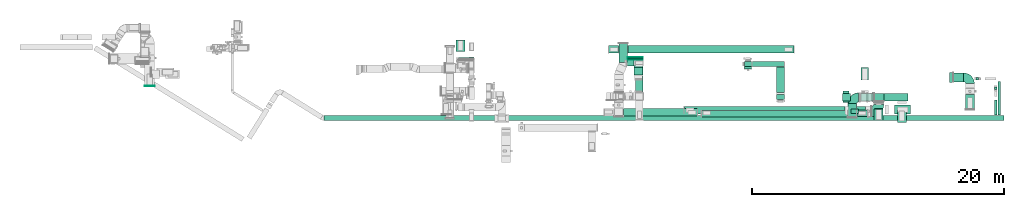
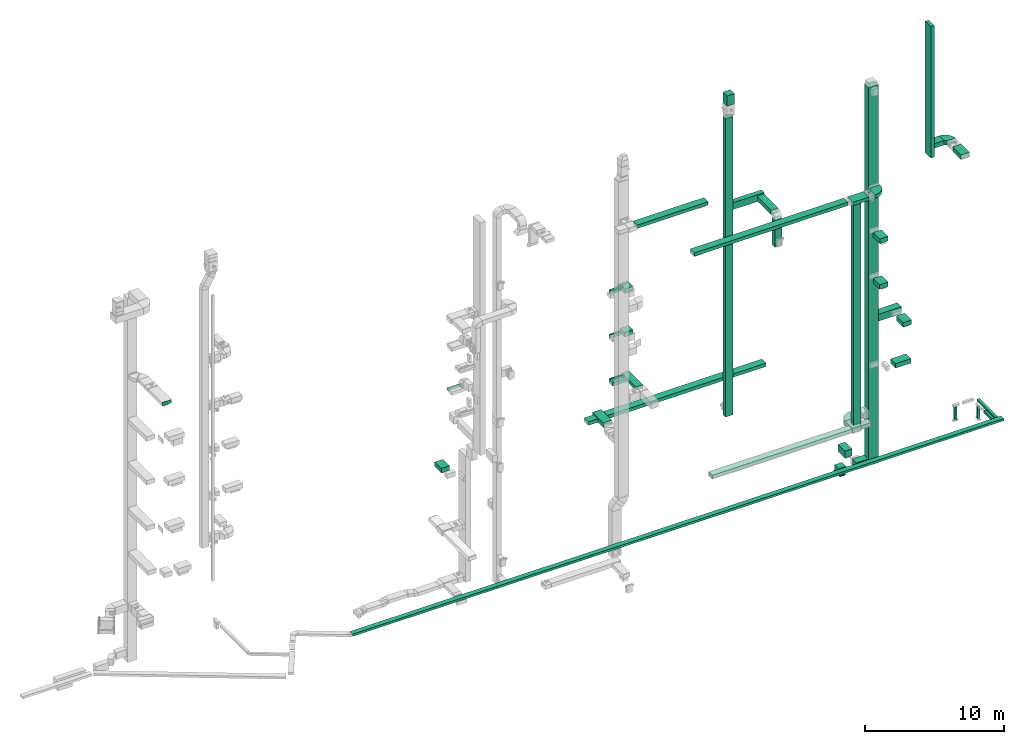
# One storey, part 8 of 25: 42 flow segments, 7 flow fittings, 2 flow terminals.
"""IFC2X3 building model written with IfcOpenShell, lengths in millimetres."""

import ifcopenshell
import ifcopenshell.guid

model = None  # the IFC model being written
_history = None  # IfcOwnerHistory: only IFC2X3 demands one
_inside = {}  # id of a spatial element -> (the spatial element, [elements in it])
_under = {}  # id of a project, library or spatial element -> (it, [spatial elements below it])
_declared = {}  # id of a project -> (the project, [libraries it declares])
_typed = {}  # id of a type object -> (the type object, [elements of that type])
_made_of = {}  # id of a material, layer set ... -> (it, [elements and type objects made of it])


def new_model(schema):
    """Start an empty IFC model of exactly this schema.

    Asked for "IFC4X3", IfcOpenShell would pick the latest addendum, in which some entities
    have other attributes; the version numbers below select the first issue.
    IFC2X3 requires an IfcOwnerHistory on every rooted entity: one is made here for all.
    """
    global model, _history
    if schema == "IFC4X3":
        model = ifcopenshell.file(schema_version=(4, 3, 0, 0))
    else:
        model = ifcopenshell.file(schema=schema)
    _inside.clear()
    _under.clear()
    _declared.clear()
    _typed.clear()
    _made_of.clear()
    _history = None
    if model.schema == "IFC2X3":
        org = make("IfcOrganization", Name="unknown")
        user = make(
            "IfcPersonAndOrganization",
            ThePerson=make("IfcPerson", FamilyName="unknown"),
            TheOrganization=org,
        )
        app = make(
            "IfcApplication",
            ApplicationDeveloper=org,
            Version="unknown",
            ApplicationFullName="unknown",
            ApplicationIdentifier="unknown",
        )
        _history = make(
            "IfcOwnerHistory",
            OwningUser=user,
            OwningApplication=app,
            ChangeAction="ADDED",
            CreationDate=0,
        )
    return model


def make(cls, **values):
    """One entity of the class cls with the attributes given. An attribute that is None is left unset."""
    return model.create_entity(
        cls, **{name: value for name, value in values.items() if value is not None}
    )


def entity(cls, *values):
    """Any entity or typed value of the class cls, its attributes in the order of the schema. None: left unset."""
    e = model.create_entity(cls)
    for i, value in enumerate(values):
        if value is not None:
            e[i] = value
    return e


def rooted(cls, **values):
    """An entity with a GlobalId (a new one), such as an element, a storey or a relation."""
    return make(cls, GlobalId=ifcopenshell.guid.new(), OwnerHistory=_history, **values)


def si_unit(unit_type, name, prefix=None):
    """IfcSIUnit, for example si_unit("LENGTHUNIT", "METRE", prefix="MILLI")."""
    return make("IfcSIUnit", UnitType=unit_type, Prefix=prefix, Name=name)


def converted_unit(unit_type, name, factor, base, dimensions=None, offset=None):
    """IfcConversionBasedUnit, such as the inch: factor (a typed value) times the base unit."""
    return make(
        "IfcConversionBasedUnit"
        if offset is None
        else "IfcConversionBasedUnitWithOffset",
        ConversionOffset=offset,
        Dimensions=None
        if dimensions is None
        else entity("IfcDimensionalExponents", *dimensions),
        UnitType=unit_type,
        Name=name,
        ConversionFactor=make(
            "IfcMeasureWithUnit", ValueComponent=factor, UnitComponent=base
        ),
    )


def derived_unit(unit_type, elements):
    """IfcDerivedUnit: a product of units, each with its exponent."""
    return make(
        "IfcDerivedUnit",
        Elements=[
            make("IfcDerivedUnitElement", Unit=unit, Exponent=power)
            for unit, power in elements
        ],
        UnitType=unit_type,
    )


def assignment(units):
    """IfcUnitAssignment: the units of a project."""
    return None if units is None else make("IfcUnitAssignment", Units=units)


def point(xyz):
    """IfcCartesianPoint."""
    return None if xyz is None else make("IfcCartesianPoint", Coordinates=xyz)


def direction(xyz):
    """IfcDirection."""
    return None if xyz is None else make("IfcDirection", DirectionRatios=xyz)


def frame(location, z_axis=None, x_axis=None):
    """IfcAxis2Placement3D, a coordinate frame: its origin and axes. An axis left out is left unset."""
    return make(
        "IfcAxis2Placement3D",
        Location=point(location),
        Axis=direction(z_axis),
        RefDirection=direction(x_axis),
    )


def frame_2d(location, x_axis=None):
    """IfcAxis2Placement2D, a coordinate frame in the plane: its origin and x axis."""
    return make(
        "IfcAxis2Placement2D", Location=point(location), RefDirection=direction(x_axis)
    )


def origin():
    """The frame at (0, 0, 0) with its axes left unset."""
    return frame((0.0, 0.0, 0.0))


def origin_2d_with_axis():
    """The frame at (0, 0) in the plane with the x axis (1, 0) written out."""
    return frame_2d((0.0, 0.0), x_axis=(1.0, 0.0))


def place(relative_to, where):
    """IfcLocalPlacement: puts the frame where relative to a parent placement (None: the world)."""
    return make(
        "IfcLocalPlacement", PlacementRelTo=relative_to, RelativePlacement=where
    )


def context(
    kind, dimensions, precision=None, world=None, true_north=None, identifier=None
):
    """IfcGeometricRepresentationContext, for example the 3D "Model" context."""
    return make(
        "IfcGeometricRepresentationContext",
        ContextIdentifier=identifier,
        ContextType=kind,
        CoordinateSpaceDimension=dimensions,
        Precision=precision,
        WorldCoordinateSystem=world,
        TrueNorth=true_north,
    )


def subcontext(parent, identifier, kind, view, scale=None):
    """IfcGeometricRepresentationSubContext, for example "Body" below "Model"."""
    return make(
        "IfcGeometricRepresentationSubContext",
        ContextIdentifier=identifier,
        ContextType=kind,
        ParentContext=parent,
        TargetScale=scale,
        TargetView=view,
    )


def project(units=None, contexts=None):
    """IfcProject with its units and contexts."""
    return rooted(
        "IfcProject",
        Name="project",
        RepresentationContexts=contexts,
        UnitsInContext=assignment(units),
    )


def spatial(cls, under=None, at=None, **own):
    """A site, building, storey or space (cls), placed at a placement, below another one or the project."""
    s = rooted(cls, ObjectPlacement=at, **own)
    if under is not None:
        _under.setdefault(under.id(), (under, []))[1].append(s)
    return s


def polyline(points):
    """IfcPolyline through the points."""
    return make("IfcPolyline", Points=[point(p) for p in points])


def circle_curve(where, radius):
    """IfcCircle in the frame where."""
    return make("IfcCircle", Position=where, Radius=radius)


def parameter(value):
    """IfcParameterValue: where a trimmed curve begins or ends, as a parameter of its basis curve."""
    return model.create_entity("IfcParameterValue", value)


def trimmed(basis, trim1, trim2, sense, master):
    """IfcTrimmedCurve: the piece of a basis curve between two trims."""
    return make(
        "IfcTrimmedCurve",
        BasisCurve=basis,
        Trim1=trim1,
        Trim2=trim2,
        SenseAgreement=sense,
        MasterRepresentation=master,
    )


def segment(curve, same_sense, transition):
    """IfcCompositeCurveSegment."""
    return make(
        "IfcCompositeCurveSegment",
        Transition=transition,
        SameSense=same_sense,
        ParentCurve=curve,
    )


def composite_curve(segments, self_intersect=None):
    """IfcCompositeCurve: segments joined end to end."""
    return make("IfcCompositeCurve", Segments=segments, SelfIntersect=self_intersect)


def profile(cls, at=None, kind="AREA", **sizes):
    """A parametric profile (cls). Its sizes go by their IFC names, for example OverallWidth=200.0."""
    return make(cls, ProfileType=kind, Position=at, **sizes)


def rectangle(**sizes):
    """IfcRectangleProfileDef."""
    return profile("IfcRectangleProfileDef", **sizes)


def outline(outer, holes=None, kind="AREA"):
    """IfcArbitraryClosedProfileDef: a profile drawn as a closed curve; with holes, ...WithVoids."""
    if holes is None:
        return make("IfcArbitraryClosedProfileDef", ProfileType=kind, OuterCurve=outer)
    return make(
        "IfcArbitraryProfileDefWithVoids",
        ProfileType=kind,
        OuterCurve=outer,
        InnerCurves=holes,
    )


def extrude(swept, where, along, depth):
    """IfcExtrudedAreaSolid: the profile swept, set in the frame where, extruded along a direction by depth."""
    return make(
        "IfcExtrudedAreaSolid",
        SweptArea=swept,
        Position=where,
        ExtrudedDirection=direction(along),
        Depth=depth,
    )


def shape(context_of_items, identifier, shape_type, items):
    """IfcShapeRepresentation: the items that make up one representation, for example the "Body"."""
    return make(
        "IfcShapeRepresentation",
        ContextOfItems=context_of_items,
        RepresentationIdentifier=identifier,
        RepresentationType=shape_type,
        Items=items,
    )


def source(mapping_origin, context_of_items, identifier, shape_type, items):
    """IfcRepresentationMap: a shape defined once, which mapped items show again and again."""
    return make(
        "IfcRepresentationMap",
        MappingOrigin=mapping_origin,
        MappedRepresentation=shape(context_of_items, identifier, shape_type, items),
    )


def transform(
    local_origin,
    x_axis=None,
    y_axis=None,
    z_axis=None,
    scale=None,
    scale2=None,
    scale3=None,
    uniform=True,
):
    """IfcCartesianTransformationOperator3D, or its non-uniform kind. x_axis, y_axis, z_axis: its Axis1, 2, 3."""
    if uniform:
        return make(
            "IfcCartesianTransformationOperator3D",
            Axis1=direction(x_axis),
            Axis2=direction(y_axis),
            LocalOrigin=point(local_origin),
            Scale=scale,
            Axis3=direction(z_axis),
        )
    return make(
        "IfcCartesianTransformationOperator3DnonUniform",
        Axis1=direction(x_axis),
        Axis2=direction(y_axis),
        LocalOrigin=point(local_origin),
        Scale=scale,
        Axis3=direction(z_axis),
        Scale2=scale2,
        Scale3=scale3,
    )


def mapped(mapping_source, mapping_target):
    """IfcMappedItem: shows the shape of a source again, moved by a transform."""
    return make(
        "IfcMappedItem", MappingSource=mapping_source, MappingTarget=mapping_target
    )


def material(Name=None, Category=None):
    """IfcMaterial."""
    return make("IfcMaterial", Name=Name, Category=Category)


def made_of(thing, what):
    """Note that an element or type object is made of a material, layer set ...; save() writes the relation."""
    if what is not None:
        _made_of.setdefault(what.id(), (what, []))[1].append(thing)
    return thing


def type_object(cls, material=None, **own):
    """A type object (cls), such as IfcWallType, which elements share."""
    return made_of(rooted(cls, **own), material)


def type_shapes(of_type, sources):
    """Give a type object the sources (RepresentationMaps) that its elements show as mapped items."""
    of_type.RepresentationMaps = sources


def element(
    cls,
    number,
    at=None,
    inside=None,
    cuts=None,
    type_object=None,
    material=None,
    context=None,
    identifier="Body",
    shape_type=None,
    held_by="IfcProductDefinitionShape",
    body=None,
    shapes=None,
    **own,
):
    """One element of the class cls, such as IfcWall. Its Tag is "e" and its number.

    at: its placement. inside: the storey or other place that contains it. cuts: it is an
    opening in that element (IfcRelVoidsElement). A single representation is given by context,
    identifier, shape_type and body (its items); several are given by shapes. held_by: the class
    of the entity that holds the representations. save() writes the other relations.
    """
    e = rooted(cls, Tag="e%d" % number, ObjectPlacement=at, **own)
    if body is not None:
        shapes = [shape(context, identifier, shape_type, body)]
    if shapes is not None:
        e.Representation = make(held_by, Representations=shapes)
    if inside is not None:
        _inside.setdefault(inside.id(), (inside, []))[1].append(e)
    if cuts is not None:
        rooted(
            "IfcRelVoidsElement", RelatingBuildingElement=cuts, RelatedOpeningElement=e
        )
    if type_object is not None:
        _typed.setdefault(type_object.id(), (type_object, []))[1].append(e)
    return made_of(e, material)


def aggregate(whole, parts):
    """IfcRelAggregates: a whole, such as a stair, and the parts it consists of."""
    return rooted("IfcRelAggregates", RelatingObject=whole, RelatedObjects=parts)


def save(model, path):
    """Write the relations noted so far, then the file.

    IfcRelAggregates (storeys below a building ...), IfcRelContainedInSpatialStructure (elements
    in a storey), IfcRelDefinesByType, IfcRelAssociatesMaterial and IfcRelDeclares: one each for
    every whole, place, type object, material and project.
    """
    for whole, parts in _under.values():
        aggregate(whole, parts)
    for where, things in _inside.values():
        rooted(
            "IfcRelContainedInSpatialStructure",
            RelatedElements=things,
            RelatingStructure=where,
        )
    for kind, things in _typed.values():
        rooted("IfcRelDefinesByType", RelatedObjects=things, RelatingType=kind)
    for what, things in _made_of.values():
        rooted("IfcRelAssociatesMaterial", RelatedObjects=things, RelatingMaterial=what)
    for by, libraries in _declared.values():
        rooted("IfcRelDeclares", RelatingContext=by, RelatedDefinitions=libraries)
    model.write(path)


model = new_model("IFC2X3")

# Units and contexts
model_context = context("Model", 3, precision=0.01, world=origin(), true_north=direction((6.12303176911189e-17, 1.0)))
body_context = subcontext(model_context, "Body", "Model", "MODEL_VIEW")
ifc_project = project(units=[si_unit("LENGTHUNIT", "METRE", prefix="MILLI"), si_unit("AREAUNIT", "SQUARE_METRE"), si_unit("VOLUMEUNIT", "CUBIC_METRE"), converted_unit("PLANEANGLEUNIT", "DEGREE", entity("IfcRatioMeasure", 0.0174532925199433), si_unit("PLANEANGLEUNIT", "RADIAN"), dimensions=[0, 0, 0, 0, 0, 0, 0]), si_unit("MASSUNIT", "GRAM", prefix="KILO"), derived_unit("MASSDENSITYUNIT", [(si_unit("MASSUNIT", "GRAM", prefix="KILO"), 1), (si_unit("LENGTHUNIT", "METRE"), -3)]), derived_unit("MOMENTOFINERTIAUNIT", [(si_unit("LENGTHUNIT", "METRE"), 4)]), si_unit("TIMEUNIT", "SECOND"), si_unit("FREQUENCYUNIT", "HERTZ"), si_unit("THERMODYNAMICTEMPERATUREUNIT", "DEGREE_CELSIUS"), derived_unit("THERMALTRANSMITTANCEUNIT", [(si_unit("MASSUNIT", "GRAM", prefix="KILO"), 1), (si_unit("THERMODYNAMICTEMPERATUREUNIT", "KELVIN"), -1), (si_unit("TIMEUNIT", "SECOND"), -3)]), derived_unit("VOLUMETRICFLOWRATEUNIT", [(si_unit("LENGTHUNIT", "METRE"), 3), (si_unit("TIMEUNIT", "SECOND"), -1)]), derived_unit("MASSFLOWRATEUNIT", [(si_unit("MASSUNIT", "GRAM", prefix="KILO"), 1), (si_unit("TIMEUNIT", "SECOND"), -1)]), derived_unit("ROTATIONALFREQUENCYUNIT", [(si_unit("TIMEUNIT", "SECOND"), -1)]), si_unit("ELECTRICCURRENTUNIT", "AMPERE"), si_unit("ELECTRICVOLTAGEUNIT", "VOLT"), si_unit("POWERUNIT", "WATT"), si_unit("FORCEUNIT", "NEWTON", prefix="KILO"), si_unit("ILLUMINANCEUNIT", "LUX"), si_unit("LUMINOUSFLUXUNIT", "LUMEN"), si_unit("LUMINOUSINTENSITYUNIT", "CANDELA"), derived_unit("USERDEFINED", [(si_unit("MASSUNIT", "GRAM", prefix="KILO"), -1), (si_unit("LENGTHUNIT", "METRE"), -2), (si_unit("TIMEUNIT", "SECOND"), 3), (si_unit("LUMINOUSFLUXUNIT", "LUMEN"), 1)]), derived_unit("LINEARVELOCITYUNIT", [(si_unit("LENGTHUNIT", "METRE"), 1), (si_unit("TIMEUNIT", "SECOND"), -1)]), si_unit("PRESSUREUNIT", "PASCAL"), derived_unit("USERDEFINED", [(si_unit("LENGTHUNIT", "METRE"), -2), (si_unit("MASSUNIT", "GRAM", prefix="KILO"), 1), (si_unit("TIMEUNIT", "SECOND"), -2)]), derived_unit("LINEARFORCEUNIT", [(si_unit("MASSUNIT", "GRAM", prefix="KILO"), 1), (si_unit("LENGTHUNIT", "METRE"), 1), (si_unit("TIMEUNIT", "SECOND"), -2), (si_unit("LENGTHUNIT", "METRE"), -1)]), derived_unit("PLANARFORCEUNIT", [(si_unit("MASSUNIT", "GRAM", prefix="KILO"), 1), (si_unit("LENGTHUNIT", "METRE"), 1), (si_unit("TIMEUNIT", "SECOND"), -2), (si_unit("LENGTHUNIT", "METRE"), -2)])], contexts=[model_context])

# Site, building, storey
site_placement = place(None, origin())
site = spatial("IfcSite", under=ifc_project, at=site_placement, CompositionType="ELEMENT")
building_placement = place(site_placement, origin())
building = spatial("IfcBuilding", under=site, at=building_placement, CompositionType="ELEMENT")
storey_placement = place(building_placement, origin())
storey = spatial("IfcBuildingStorey", under=building, at=storey_placement, CompositionType="ELEMENT", Elevation=0.0)

# Flow segments
duct_segment_type = type_object("IfcDuctSegmentType", PredefinedType="NOTDEFINED")
flow_segment_1_placement = place(storey_placement, frame((29480.94, 13826.02, 14200.0)))
element("IfcFlowSegment", 1, at=flow_segment_1_placement, inside=storey, type_object=duct_segment_type, context=body_context, shape_type="SweptSolid", body=[
    extrude(rectangle(XDim=149.999999999951, YDim=1200.0, at=origin_2d_with_axis()), frame((600.0, 75.0, 0.0), z_axis=(0.0, 0.0, 1.0), x_axis=(0.0, -1.0, 0.0)), (0.0, 0.0, 1.0), 199.999999999998),
])
flow_segment_2_placement = place(storey_placement, frame((29270.05, 14439.7, 6700.0)))
element("IfcFlowSegment", 2, at=flow_segment_2_placement, inside=storey, type_object=duct_segment_type, context=body_context, shape_type="SweptSolid", body=[
    extrude(rectangle(XDim=937.535158670706, YDim=700.000000000001, at=origin_2d_with_axis()), frame((350.0, 468.77, 0.0), z_axis=(0.0, 0.0, 1.0), x_axis=(0.0, -1.0, 0.0)), (0.0, 0.0, 1.0), 400.0),
])
flow_segment_3_placement = place(storey_placement, frame((68487.5, 11992.6, 22100.0)))
element("IfcFlowSegment", 3, at=flow_segment_3_placement, inside=storey, type_object=duct_segment_type, context=body_context, shape_type="SweptSolid", body=[
    extrude(rectangle(XDim=300.000000000001, YDim=800.0, at=origin_2d_with_axis()), frame((150.0, 400.0, 0.0), z_axis=(0.0, 0.0, 1.0), x_axis=(-1.0, 0.0, 0.0)), (0.0, 0.0, 1.0), 11520.0),
])
flow_segment_4_placement = place(storey_placement, frame((68807.5, 12049.6, 22800.0)))
element("IfcFlowSegment", 4, at=flow_segment_4_placement, inside=storey, type_object=duct_segment_type, context=body_context, shape_type="SweptSolid", body=[
    extrude(rectangle(XDim=812.397954617454, YDim=700.000000000001, at=origin_2d_with_axis()), frame((406.2, 350.0, 0.0), z_axis=(0.0, 0.0, 1.0), x_axis=(-1.0, 0.0, 0.0)), (0.0, 0.0, 1.0), 399.999999999996),
])
flow_segment_5_placement = place(storey_placement, frame((69769.9, 9867.9, 22800.0)))
element("IfcFlowSegment", 5, at=flow_segment_5_placement, inside=storey, type_object=duct_segment_type, context=body_context, shape_type="SweptSolid", body=[
    extrude(rectangle(XDim=1187.09543420805, YDim=699.999999999997, at=origin_2d_with_axis()), frame((350.0, 593.55, 0.0), z_axis=(0.0, 0.0, 1.0), x_axis=(0.0, -1.0, 0.0)), (0.0, 0.0, 1.0), 399.999999999996),
])
flow_segment_6_placement = place(storey_placement, frame((52184.97, 13247.51, 4300.0)))
element("IfcFlowSegment", 6, at=flow_segment_6_placement, inside=storey, type_object=duct_segment_type, context=body_context, shape_type="SweptSolid", body=[
    extrude(rectangle(XDim=400.0, YDim=600.000000000002, at=origin_2d_with_axis()), frame((300.0, 200.0, 0.0), z_axis=(0.0, 0.0, 1.0), x_axis=(0.0, 1.0, 0.0)), (0.0, 0.0, 1.0), 26200.0),
])
flow_segment_7_placement = place(storey_placement, frame((52804.97, 13249.51, 22300.0)))
element("IfcFlowSegment", 7, at=flow_segment_7_placement, inside=storey, type_object=duct_segment_type, context=body_context, shape_type="SweptSolid", body=[
    extrude(rectangle(XDim=2571.24040529866, YDim=400.0, at=origin_2d_with_axis()), frame((1285.62, 200.0, 0.0)), (0.0, 0.0, 1.0), 600.000000000002),
])
flow_segment_8_placement = place(storey_placement, frame((54760.3, 11177.51, 22400.0)))
element("IfcFlowSegment", 8, at=flow_segment_8_placement, inside=storey, type_object=duct_segment_type, context=body_context, shape_type="SweptSolid", body=[
    extrude(rectangle(XDim=2051.99999999995, YDim=600.000000000002, at=origin_2d_with_axis()), frame((300.0, 1026.0, 0.0), z_axis=(0.0, 0.0, 1.0), x_axis=(0.0, -1.0, 0.0)), (0.0, 0.0, 1.0), 399.999999999996),
])
flow_segment_9_placement = place(storey_placement, frame((54760.3, 10627.51, 19900.0)))
element("IfcFlowSegment", 9, at=flow_segment_9_placement, inside=storey, type_object=duct_segment_type, context=body_context, shape_type="SweptSolid", body=[
    extrude(rectangle(XDim=600.000000000002, YDim=400.0, at=origin_2d_with_axis()), frame((300.0, 200.0, 0.0)), (0.0, 0.0, 1.0), 2350.0),
])
flow_segment_10_placement = place(storey_placement, frame((62470.59, 10508.5, -1899.51)))
element("IfcFlowSegment", 10, at=flow_segment_10_placement, inside=storey, type_object=duct_segment_type, context=body_context, shape_type="SweptSolid", body=[
    extrude(rectangle(XDim=600.000000000002, YDim=800.0, at=origin_2d_with_axis()), frame((400.0, 300.0, 0.0), z_axis=(0.0, 0.0, 1.0), x_axis=(0.0, 1.0, 0.0)), (0.0, 0.0, 1.0), 33180.0000000001),
])
flow_segment_11_placement = place(storey_placement, frame((47415.34, 9499.96, 22350.0)))
element("IfcFlowSegment", 11, at=flow_segment_11_placement, inside=storey, type_object=duct_segment_type, context=body_context, shape_type="SweptSolid", body=[
    extrude(rectangle(XDim=12760.06238009, YDim=599.999999999999, at=origin_2d_with_axis()), frame((6380.04, 300.09, 0.0), z_axis=(0.0, 0.0, 1.0), x_axis=(-1.0, -1.46520719766494e-05, 0.0)), (0.0, 0.0, 1.0), 300.000000000001),
])
flow_segment_12_placement = place(storey_placement, frame((60654.85, 9545.45, 2395.0)))
element("IfcFlowSegment", 12, at=flow_segment_12_placement, inside=storey, type_object=duct_segment_type, context=body_context, shape_type="SweptSolid", body=[
    extrude(rectangle(XDim=624.999999999996, YDim=325.000000000001, at=origin_2d_with_axis()), frame((312.5, 162.5, 0.0), z_axis=(0.0, 0.0, 1.0), x_axis=(-1.0, 0.0, 0.0)), (0.0, 0.0, 1.0), 19935.0),
])
flow_segment_13_placement = place(storey_placement, frame((63290.59, 10508.5, 10500.0)))
element("IfcFlowSegment", 13, at=flow_segment_13_placement, inside=storey, type_object=duct_segment_type, context=body_context, shape_type="SweptSolid", body=[
    extrude(rectangle(XDim=1899.05121432152, YDim=600.0, at=origin_2d_with_axis()), frame((949.53, 300.0, 0.0)), (0.0, 0.0, 1.0), 600.000000000002),
])
flow_segment_14_placement = place(storey_placement, frame((62507.05, 8974.84, 14500.0)))
element("IfcFlowSegment", 14, at=flow_segment_14_placement, inside=storey, type_object=duct_segment_type, context=body_context, shape_type="SweptSolid", body=[
    extrude(rectangle(XDim=924.752466860906, YDim=699.999999999997, at=origin_2d_with_axis()), frame((350.0, 462.38, 0.0), z_axis=(0.0, 0.0, 1.0), x_axis=(0.0, -1.0, 0.0)), (0.0, 0.0, 1.0), 400.0),
])
flow_segment_15_placement = place(storey_placement, frame((62519.04, 8984.84, 18500.0)))
element("IfcFlowSegment", 15, at=flow_segment_15_placement, inside=storey, type_object=duct_segment_type, context=body_context, shape_type="SweptSolid", body=[
    extrude(rectangle(XDim=947.818216633924, YDim=699.999999999997, at=origin_2d_with_axis()), frame((350.0, 473.91, 0.0), z_axis=(0.0, 0.0, 1.0), x_axis=(0.0, 1.0, 0.0)), (0.0, 0.0, 1.0), 400.0),
])
flow_segment_16_placement = place(storey_placement, frame((48788.45, 9267.34, 2500.0)))
element("IfcFlowSegment", 16, at=flow_segment_16_placement, inside=storey, type_object=duct_segment_type, context=body_context, shape_type="SweptSolid", body=[
    extrude(rectangle(XDim=11604.0416533364, YDim=500.0, at=origin_2d_with_axis()), frame((5802.02, 250.0, 0.0)), (0.0, 0.0, 1.0), 300.0),
])
flow_segment_17_placement = place(storey_placement, frame((61132.5, 9300.08, 2500.0)))
element("IfcFlowSegment", 17, at=flow_segment_17_placement, inside=storey, type_object=duct_segment_type, context=body_context, shape_type="SweptSolid", body=[
    extrude(rectangle(XDim=831.78346095215, YDim=499.999999999999, at=origin_2d_with_axis()), frame((415.89, 250.0, 0.0), z_axis=(0.0, 0.0, 1.0), x_axis=(-1.0, 0.0, 0.0)), (0.0, 0.0, 1.0), 300.0),
])
flow_segment_18_placement = place(storey_placement, frame((59985.32, 10508.5, -1899.51)))
element("IfcFlowSegment", 18, at=flow_segment_18_placement, inside=storey, type_object=duct_segment_type, context=body_context, shape_type="SweptSolid", body=[
    extrude(rectangle(XDim=632.577535598582, YDim=600.0, at=origin_2d_with_axis()), frame((316.29, 300.0, 0.0), z_axis=(0.0, 0.0, 1.0), x_axis=(-1.0, 0.0, 0.0)), (0.0, 0.0, 1.0), 600.0),
])
flow_segment_19_placement = place(storey_placement, frame((61470.14, 12189.72, -1899.51)))
element("IfcFlowSegment", 19, at=flow_segment_19_placement, inside=storey, type_object=duct_segment_type, context=body_context, shape_type="SweptSolid", body=[
    extrude(rectangle(XDim=1004.44112420994, YDim=600.000000000002, at=origin_2d_with_axis()), frame((300.0, 502.22, 0.0), z_axis=(0.0, 0.0, 1.0), x_axis=(0.0, -1.0, 0.0)), (0.0, 0.0, 1.0), 600.0),
])
flow_segment_20_placement = place(storey_placement, frame((60021.61, 10407.35, -1980.0)))
element("IfcFlowSegment", 20, at=flow_segment_20_placement, inside=storey, type_object=duct_segment_type, context=body_context, shape_type="SweptSolid", body=[
    extrude(rectangle(XDim=900.000000000001, YDim=499.999999999997, at=origin_2d_with_axis()), frame((250.0, 450.0, 0.0), z_axis=(0.0, 0.0, 1.0), x_axis=(-5.14107242270256e-06, -1.0, 0.0)), (0.0, 0.0, 1.0), 60.4869889686082),
])
flow_segment_21_placement = place(storey_placement, frame((61457.9, 10508.5, -1899.51)))
element("IfcFlowSegment", 21, at=flow_segment_21_placement, inside=storey, type_object=duct_segment_type, context=body_context, shape_type="SweptSolid", body=[
    extrude(rectangle(XDim=992.690461747766, YDim=600.0, at=origin_2d_with_axis()), frame((496.35, 300.0, 0.0), z_axis=(0.0, 0.0, 1.0), x_axis=(-1.0, 0.0, 0.0)), (0.0, 0.0, 1.0), 600.0),
])
flow_segment_22_placement = place(storey_placement, frame((18783.28, 8980.0, -650.0)))
element("IfcFlowSegment", 22, at=flow_segment_22_placement, inside=storey, type_object=duct_segment_type, context=body_context, shape_type="SweptSolid", body=[
    extrude(rectangle(XDim=54040.2939500627, YDim=400.0, at=origin_2d_with_axis()), frame((27020.15, 200.0, 0.0), z_axis=(0.0, 0.0, 1.0), x_axis=(-1.0, 0.0, 0.0)), (0.0, 0.0, 1.0), 200.0),
])
flow_segment_23_placement = place(storey_placement, frame((72354.33, 9400.0, -650.0)))
element("IfcFlowSegment", 23, at=flow_segment_23_placement, inside=storey, type_object=duct_segment_type, context=body_context, shape_type="SweptSolid", body=[
    extrude(rectangle(XDim=2655.49980810698, YDim=199.999999999998, at=origin_2d_with_axis()), frame((100.0, 1327.75, 0.0), z_axis=(0.0, 0.0, 1.0), x_axis=(0.0, -1.0, 0.0)), (0.0, 0.0, 1.0), 200.0),
])
flow_segment_24_placement = place(storey_placement, frame((72050.46, 9400.0, -650.0)))
element("IfcFlowSegment", 24, at=flow_segment_24_placement, inside=storey, type_object=duct_segment_type, context=body_context, shape_type="SweptSolid", body=[
    extrude(rectangle(XDim=1187.25694943575, YDim=199.999999999998, at=origin_2d_with_axis()), frame((100.0, 593.63, 0.0), z_axis=(0.0, 0.0, 1.0), x_axis=(0.0, 1.0, 0.0)), (0.0, 0.0, 1.0), 200.0),
])
flow_segment_25_placement = place(storey_placement, frame((70599.23, 12205.5, -1774.0)))
element("IfcFlowSegment", 25, at=flow_segment_25_placement, inside=storey, type_object=duct_segment_type, context=body_context, shape_type="SweptSolid", body=[
    extrude(rectangle(XDim=200.000000000002, YDim=199.999999999998, at=origin_2d_with_axis()), frame((100.0, 100.0, 0.0), z_axis=(0.0, 0.0, 1.0), x_axis=(0.0, 1.0, 0.0)), (0.0, 0.0, 1.0), 1104.00000000002),
])
flow_segment_26_placement = place(storey_placement, frame((72050.46, 11424.9, -1680.0)))
element("IfcFlowSegment", 26, at=flow_segment_26_placement, inside=storey, type_object=duct_segment_type, context=body_context, shape_type="SweptSolid", body=[
    extrude(rectangle(XDim=200.000000000007, YDim=200.0, at=origin_2d_with_axis()), frame((100.0, 100.0, 0.0)), (0.0, 0.0, 1.0), 1010.00000000001),
])
flow_segment_27_placement = place(storey_placement, frame((42574.87, 9319.58, 26600.0)))
element("IfcFlowSegment", 27, at=flow_segment_27_placement, inside=storey, type_object=duct_segment_type, context=body_context, shape_type="SweptSolid", body=[
    extrude(rectangle(XDim=5885.0094274255, YDim=600.0, at=origin_2d_with_axis()), frame((2942.5, 300.0, 0.0), z_axis=(0.0, 0.0, 1.0), x_axis=(-1.0, 0.0, 0.0)), (0.0, 0.0, 1.0), 300.000000000001),
])
flow_segment_28_placement = place(storey_placement, frame((43430.54, 12587.49, 18600.0)))
element("IfcFlowSegment", 28, at=flow_segment_28_placement, inside=storey, type_object=duct_segment_type, context=body_context, shape_type="SweptSolid", body=[
    extrude(rectangle(XDim=600.000000000067, YDim=699.999999999997, at=origin_2d_with_axis()), frame((350.0, 300.0, 0.0), z_axis=(0.0, 0.0, 1.0), x_axis=(0.0, -1.0, 0.0)), (0.0, 0.0, 1.0), 400.0),
])
flow_segment_29_placement = place(storey_placement, frame((43550.6, 11204.99, 10900.0)))
element("IfcFlowSegment", 29, at=flow_segment_29_placement, inside=storey, type_object=duct_segment_type, context=body_context, shape_type="SweptSolid", body=[
    extrude(rectangle(XDim=2055.01024767937, YDim=600.000000000002, at=origin_2d_with_axis()), frame((300.0, 1027.51, 0.0), z_axis=(0.0, 0.0, 1.0), x_axis=(0.0, 1.0, 0.0)), (0.0, 0.0, 1.0), 300.000000000001),
])
flow_segment_30_placement = place(storey_placement, frame((42920.54, 13807.49, 18000.0)))
element("IfcFlowSegment", 30, at=flow_segment_30_placement, inside=storey, type_object=duct_segment_type, context=body_context, shape_type="SweptSolid", body=[
    extrude(rectangle(XDim=167.510937173448, YDim=1200.0, at=origin_2d_with_axis()), frame((600.0, 83.76, 0.0), z_axis=(0.0, 0.0, 1.0), x_axis=(0.0, -1.0, 0.0)), (0.0, 0.0, 1.0), 300.000000000001),
])
flow_segment_31_placement = place(storey_placement, frame((43410.26, 12584.99, 14800.0)))
element("IfcFlowSegment", 31, at=flow_segment_31_placement, inside=storey, type_object=duct_segment_type, context=body_context, shape_type="SweptSolid", body=[
    extrude(rectangle(XDim=632.499353737754, YDim=699.999999999997, at=origin_2d_with_axis()), frame((350.0, 316.25, 0.0), z_axis=(0.0, 0.0, 1.0), x_axis=(0.0, -1.0, 0.0)), (0.0, 0.0, 1.0), 400.0),
])
flow_segment_32_placement = place(storey_placement, frame((42920.54, 13837.49, 14100.0)))
element("IfcFlowSegment", 32, at=flow_segment_32_placement, inside=storey, type_object=duct_segment_type, context=body_context, shape_type="SweptSolid", body=[
    extrude(rectangle(XDim=137.510937173448, YDim=1200.0, at=origin_2d_with_axis()), frame((600.0, 68.76, 0.0), z_axis=(0.0, 0.0, 1.0), x_axis=(0.0, -1.0, 0.0)), (0.0, 0.0, 1.0), 300.000000000001),
])
flow_segment_33_placement = place(storey_placement, frame((42847.67, 13317.49, 10250.0)))
element("IfcFlowSegment", 33, at=flow_segment_33_placement, inside=storey, type_object=duct_segment_type, context=body_context, shape_type="SweptSolid", body=[
    extrude(rectangle(XDim=1300.0, YDim=499.999999999999, at=origin_2d_with_axis()), frame((650.0, 250.0, 0.0), z_axis=(0.0, 0.0, 1.0), x_axis=(-1.0, 0.0, 0.0)), (0.0, 0.0, 1.0), 300.000000000001),
])
flow_segment_34_placement = place(storey_placement, frame((42939.85, 14330.07, 6700.0)))
element("IfcFlowSegment", 34, at=flow_segment_34_placement, inside=storey, type_object=duct_segment_type, context=body_context, shape_type="SweptSolid", body=[
    extrude(rectangle(XDim=13206.0535856904, YDim=600.0, at=origin_2d_with_axis()), frame((6603.03, 300.0, 0.0), z_axis=(0.0, 0.0, 1.0), x_axis=(-1.0, 0.0, 0.0)), (0.0, 0.0, 1.0), 300.000000000001),
])
flow_segment_35_placement = place(storey_placement, frame((41411.79, 14330.07, 6700.0)))
element("IfcFlowSegment", 35, at=flow_segment_35_placement, inside=storey, type_object=duct_segment_type, context=body_context, shape_type="SweptSolid", body=[
    extrude(rectangle(XDim=788.053179273669, YDim=600.0, at=origin_2d_with_axis()), frame((394.03, 300.0, 0.0)), (0.0, 0.0, 1.0), 300.000000000001),
])
flow_segment_36_placement = place(storey_placement, frame((42219.85, 13563.14, 6700.0)))
element("IfcFlowSegment", 36, at=flow_segment_36_placement, inside=storey, type_object=duct_segment_type, context=body_context, shape_type="SweptSolid", body=[
    extrude(rectangle(XDim=1542.05774942284, YDim=699.999999999997, at=origin_2d_with_axis()), frame((350.0, 771.03, 0.0), z_axis=(0.0, 0.0, 1.0), x_axis=(0.0, 1.0, 0.0)), (0.0, 0.0, 1.0), 400.0),
])
flow_segment_37_placement = place(storey_placement, frame((42920.54, 13837.49, 10300.0)))
element("IfcFlowSegment", 37, at=flow_segment_37_placement, inside=storey, type_object=duct_segment_type, context=body_context, shape_type="SweptSolid", body=[
    extrude(rectangle(XDim=137.510893630899, YDim=1200.0, at=origin_2d_with_axis()), frame((600.0, 68.76, 0.0), z_axis=(0.0, 0.0, 1.0), x_axis=(0.0, -1.0, 0.0)), (0.0, 0.0, 1.0), 199.999999999998),
])
flow_segment_38_placement = place(storey_placement, frame((60475.09, 9299.13, 22350.0)))
element("IfcFlowSegment", 38, at=flow_segment_38_placement, inside=storey, type_object=duct_segment_type, context=body_context, shape_type="SweptSolid", body=[
    extrude(rectangle(XDim=1324.08735347574, YDim=800.0, at=origin_2d_with_axis()), frame((662.29, 400.41, 0.0), z_axis=(0.0, 0.0, 1.0), x_axis=(-0.999999805808052, 0.000623204507744216, 0.0)), (0.0, 0.0, 1.0), 300.000000000001),
])
flow_segment_39_placement = place(storey_placement, frame((60412.5, 9250.09, 2450.0)))
element("IfcFlowSegment", 39, at=flow_segment_39_placement, inside=storey, type_object=duct_segment_type, context=body_context, shape_type="SweptSolid", body=[
    extrude(rectangle(XDim=1058.41426556729, YDim=699.999999999997, at=origin_2d_with_axis()), frame((350.0, 529.21, 0.0), z_axis=(0.0, 0.0, 1.0), x_axis=(0.0, -1.0, 0.0)), (0.0, 0.0, 1.0), 400.0),
])
flow_segment_40_placement = place(storey_placement, frame((64110.0, 9485.42, 6700.0)))
element("IfcFlowSegment", 40, at=flow_segment_40_placement, inside=storey, type_object=duct_segment_type, context=body_context, shape_type="SweptSolid", body=[
    extrude(rectangle(XDim=1288.00000000007, YDim=700.0, at=origin_2d_with_axis()), frame((644.0, 350.0, 0.0)), (0.0, 0.0, 1.0), 400.0),
])
flow_segment_41_placement = place(storey_placement, frame((64372.35, 8827.66, 10600.0)))
element("IfcFlowSegment", 41, at=flow_segment_41_placement, inside=storey, type_object=duct_segment_type, context=body_context, shape_type="SweptSolid", body=[
    extrude(rectangle(XDim=998.000000000008, YDim=699.999999999997, at=origin_2d_with_axis()), frame((350.0, 499.0, 0.0), z_axis=(0.0, 0.0, 1.0), x_axis=(0.0, -1.0, 0.0)), (0.0, 0.0, 1.0), 400.0),
])
flow_segment_42_placement = place(storey_placement, frame((52184.97, 13047.51, 31710.0)))
element("IfcFlowSegment", 42, at=flow_segment_42_placement, inside=storey, type_object=duct_segment_type, context=body_context, shape_type="SweptSolid", body=[
    extrude(rectangle(XDim=600.0, YDim=600.000000000002, at=origin_2d_with_axis()), frame((300.0, 300.0, 0.0), z_axis=(0.0, 0.0, 1.0), x_axis=(0.0, -1.0, 0.0)), (0.0, 0.0, 1.0), 890.000000000062),
])

# Flow terminals
ifc_material_1 = material()
air_terminal_type_1 = type_object("IfcAirTerminalType", PredefinedType="NOTDEFINED", material=ifc_material_1)
shared_shape_1 = source(origin(), body_context, "Body", "SweptSolid", [
    extrude(rectangle(XDim=4.0, YDim=1200.0, at=origin_2d_with_axis()), frame((0.0, -2.0, -100.0), z_axis=(0.0, 0.0, 1.0), x_axis=(0.0, 1.0, 0.0)), (0.0, 0.0, 1.0), 200.000000000005),
])
type_shapes(air_terminal_type_1, [shared_shape_1])
flow_terminal_1_placement = place(storey_placement, frame((43520.54, 13975.0, 10400.0), z_axis=(0.0, 0.0, 1.0), x_axis=(-1.0, 0.0, 0.0)))
element("IfcFlowTerminal", 43, at=flow_terminal_1_placement, inside=storey, type_object=air_terminal_type_1, material=ifc_material_1, context=body_context, shape_type="MappedRepresentation", body=[
    mapped(shared_shape_1, transform((0.0, 0.0, 0.0), scale=1.0)),
])
air_terminal_type_2 = type_object("IfcAirTerminalType", PredefinedType="NOTDEFINED", material=ifc_material_1)
shared_shape_2 = source(origin(), body_context, "Body", "SweptSolid", [
    extrude(rectangle(XDim=4.0, YDim=1200.0, at=origin_2d_with_axis()), frame((0.0, -2.0, -150.0), z_axis=(0.0, 0.0, 1.0), x_axis=(0.0, 1.0, 0.0)), (0.0, 0.0, 1.0), 300.000000000005),
])
type_shapes(air_terminal_type_2, [shared_shape_2])
flow_terminal_2_placement = place(storey_placement, frame((43520.54, 13975.0, 18150.0), z_axis=(0.0, 0.0, -1.0), x_axis=(1.0, 0.0, 0.0)))
element("IfcFlowTerminal", 44, at=flow_terminal_2_placement, inside=storey, type_object=air_terminal_type_2, material=ifc_material_1, context=body_context, shape_type="MappedRepresentation", body=[
    mapped(shared_shape_2, transform((0.0, 0.0, 0.0), scale=1.0)),
])

# Flow fittings
ifc_material_2 = material()
duct_fitting_type_1 = type_object("IfcDuctFittingType", PredefinedType="NOTDEFINED", material=ifc_material_2)
shared_shape_3 = source(origin(), body_context, "Body", "SweptSolid", [
    extrude(rectangle(XDim=1200.0, YDim=26.0960000000043, at=origin_2d_with_axis()), frame((6.95, 0.0, -150.0), z_axis=(0.0, 0.0, 1.0), x_axis=(0.0, -1.0, 0.0)), (0.0, 0.0, 1.0), 300.0),
])
type_shapes(duct_fitting_type_1, [shared_shape_3])
flow_fitting_1_placement = place(storey_placement, frame((43520.54, 13787.49, 18150.0), z_axis=(0.0, 0.0, -1.0), x_axis=(0.0, 1.0, 0.0)))
element("IfcFlowFitting", 45, at=flow_fitting_1_placement, inside=storey, type_object=duct_fitting_type_1, material=ifc_material_2, context=body_context, shape_type="MappedRepresentation", body=[
    mapped(shared_shape_3, transform((0.0, 0.0, 0.0), scale=1.0)),
])
duct_fitting_type_2 = type_object("IfcDuctFittingType", PredefinedType="NOTDEFINED", material=ifc_material_2)
shared_shape_4 = source(origin(), body_context, "Body", "SweptSolid", [
    extrude(rectangle(XDim=26.0960000000062, YDim=1200.0, at=origin_2d_with_axis()), frame((6.95, 0.0, -100.0)), (0.0, 0.0, 1.0), 200.0),
])
type_shapes(duct_fitting_type_2, [shared_shape_4])
flow_fitting_2_placement = place(storey_placement, frame((43520.54, 13817.49, 10400.0), z_axis=(0.0, 0.0, -1.0), x_axis=(0.0, 1.0, 0.0)))
element("IfcFlowFitting", 46, at=flow_fitting_2_placement, inside=storey, type_object=duct_fitting_type_2, material=ifc_material_2, context=body_context, shape_type="MappedRepresentation", body=[
    mapped(shared_shape_4, transform((0.0, 0.0, 0.0), scale=1.0)),
])
duct_fitting_type_3 = type_object("IfcDuctFittingType", PredefinedType="NOTDEFINED", material=ifc_material_2)
shared_shape_5 = source(origin(), body_context, "Body", "SweptSolid", [
    extrude(rectangle(XDim=24.9999999999999, YDim=800.0, at=origin_2d_with_axis()), frame((12.5, 0.0, -150.0)), (0.0, 0.0, 1.0), 300.0),
])
type_shapes(duct_fitting_type_3, [shared_shape_5])
flow_fitting_3_placement = place(storey_placement, frame((4919.66, 11729.53, 23050.0), z_axis=(0.0, 0.0, 1.0), x_axis=(0.0, -1.0, 0.0)))
element("IfcFlowFitting", 47, at=flow_fitting_3_placement, inside=storey, type_object=duct_fitting_type_3, material=ifc_material_2, context=body_context, shape_type="MappedRepresentation", body=[
    mapped(shared_shape_5, transform((0.0, 0.0, 0.0), scale=1.0)),
])
duct_fitting_type_4 = type_object("IfcDuctFittingType", PredefinedType="NOTDEFINED", material=ifc_material_2)
shared_shape_6 = source(origin(), body_context, "Body", "SweptSolid", [
    extrude(outline(composite_curve([segment(polyline([(-675.0, -275.0), (125.0, -275.0)]), True, "CONTINUOUS"), segment(trimmed(circle_curve(frame_2d((275.0, -275.0), x_axis=(0.0, 1.0)), 150.0), [parameter(0.0)], [parameter(90.0000000000001)], True, "PARAMETER"), False, "CONTINUOUS"), segment(polyline([(275.0, -125.0), (275.0, 675.0)]), True, "CONTINUOUS"), segment(trimmed(circle_curve(frame_2d((275.0, -275.0), x_axis=(0.0, 1.0)), 950.0), [parameter(0.0)], [parameter(90.0000000000001)], True, "PARAMETER"), True, "CONTINUOUS")], self_intersect=False)), frame((-275.0, 275.0, -150.0), z_axis=(0.0, 0.0, 1.0), x_axis=(-1.0, 0.0, 0.0)), (0.0, 0.0, 1.0), 300.0),
])
type_shapes(duct_fitting_type_4, [shared_shape_6])
flow_fitting_4_placement = place(storey_placement, frame((62869.72, 9698.83, 22500.0)))
element("IfcFlowFitting", 48, at=flow_fitting_4_placement, inside=storey, type_object=duct_fitting_type_4, material=ifc_material_2, context=body_context, shape_type="MappedRepresentation", body=[
    mapped(shared_shape_6, transform((0.0, 0.0, 0.0), scale=1.0)),
])
duct_fitting_type_5 = type_object("IfcDuctFittingType", PredefinedType="NOTDEFINED", material=ifc_material_2)
shared_shape_7 = source(origin(), body_context, "Body", "SweptSolid", [
    extrude(outline(composite_curve([segment(polyline([(-600.0, -250.0), (100.0, -250.0)]), True, "CONTINUOUS"), segment(trimmed(circle_curve(frame_2d((250.0, -250.0), x_axis=(0.0, 1.0)), 150.0), [parameter(0.0)], [parameter(90.0)], True, "PARAMETER"), False, "CONTINUOUS"), segment(polyline([(250.0, -100.0), (250.0, 600.0)]), True, "CONTINUOUS"), segment(trimmed(circle_curve(frame_2d((250.0, -250.0), x_axis=(0.0, 1.0)), 850.0), [parameter(0.0)], [parameter(90.0)], True, "PARAMETER"), True, "CONTINUOUS")], self_intersect=False)), frame((-250.0, 250.0, -200.0), z_axis=(0.0, 0.0, 1.0), x_axis=(-1.0, 0.0, 0.0)), (0.0, 0.0, 1.0), 400.0),
])
type_shapes(duct_fitting_type_5, [shared_shape_7])
for number, where, z_axis, x_axis in (
    (49, (70119.9, 12399.6, 23000.0), (0.0, 0.0, 1.0), (0.0, 1.0, 0.0)),
    (50, (60762.5, 10808.5, 2650.0), (0.0, 0.0, 1.0), (-1.0, 0.0, 0.0)),
):
    element("IfcFlowFitting", number, at=place(storey_placement, frame(where, z_axis=z_axis, x_axis=x_axis)), inside=storey, type_object=duct_fitting_type_5, material=ifc_material_2, context=body_context, shape_type="MappedRepresentation", body=[
        mapped(shared_shape_7, transform((0.0, 0.0, 0.0), scale=1.0)),
    ])
duct_fitting_type_6 = type_object("IfcDuctFittingType", PredefinedType="NOTDEFINED", material=ifc_material_2)
shared_shape_8 = source(origin(), body_context, "Body", "SweptSolid", [
    extrude(outline(composite_curve([segment(polyline([(-375.0, -175.0), (25.0, -175.0)]), True, "CONTINUOUS"), segment(trimmed(circle_curve(frame_2d((175.0, -175.0), x_axis=(0.0, 1.0)), 150.0), [parameter(0.0)], [parameter(90.0000000000001)], True, "PARAMETER"), False, "CONTINUOUS"), segment(polyline([(175.0, -25.0), (175.0, 375.0)]), True, "CONTINUOUS"), segment(trimmed(circle_curve(frame_2d((175.0, -175.0), x_axis=(0.0, 1.0)), 550.0), [parameter(0.0)], [parameter(90.0)], True, "PARAMETER"), True, "CONTINUOUS")], self_intersect=False)), frame((-175.0, 175.0, -350.0), z_axis=(0.0, 0.0, 1.0), x_axis=(-1.0, 0.0, 0.0)), (0.0, 0.0, 1.0), 700.0),
])
type_shapes(duct_fitting_type_6, [shared_shape_8])
flow_fitting_5_placement = place(storey_placement, frame((43780.54, 13537.49, 18800.0), z_axis=(1.0, 0.0, 0.0), x_axis=(0.0, 0.0, 1.0)))
element("IfcFlowFitting", 51, at=flow_fitting_5_placement, inside=storey, type_object=duct_fitting_type_6, material=ifc_material_2, context=body_context, shape_type="MappedRepresentation", body=[
    mapped(shared_shape_8, transform((0.0, 0.0, 0.0), scale=1.0)),
])

save(model, "model.ifc")
